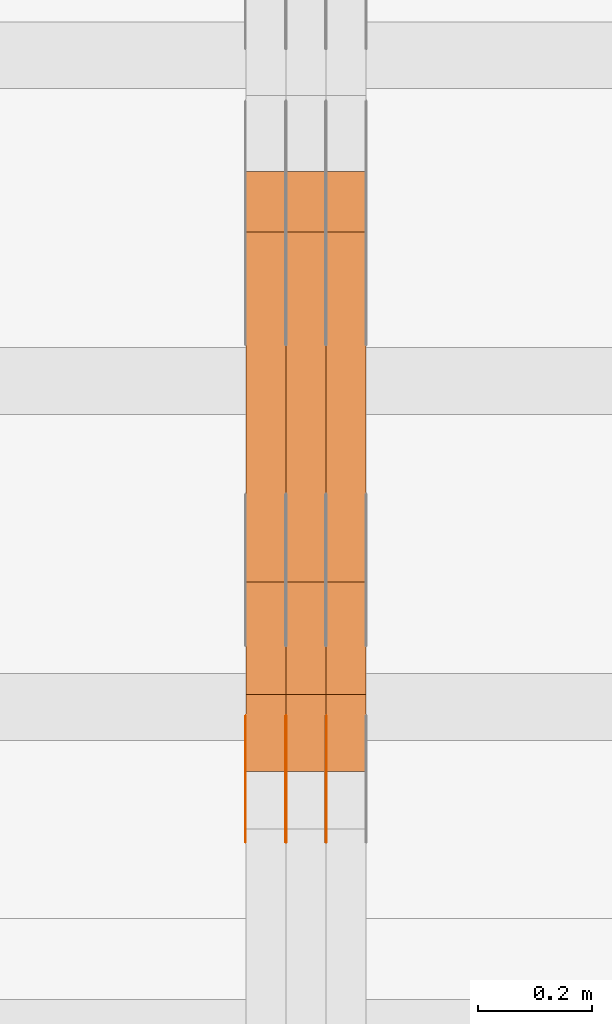
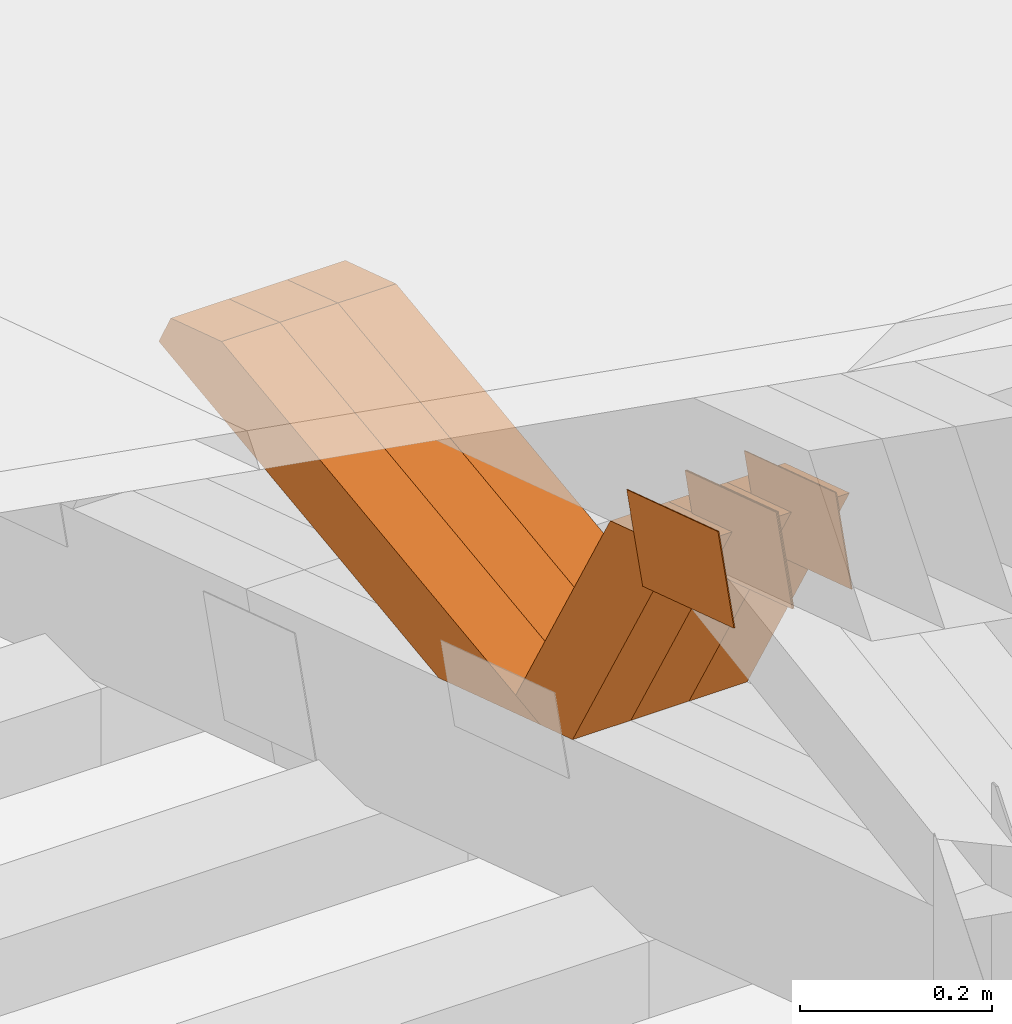
# One storey, part 169 of 385: 10 proxies.
"""IFC2X3 building model written with IfcOpenShell, lengths in millimetres."""

from ifc_helpers import new_model, entity, si_unit, converted_unit, derived_unit, direction, frame, origin, place, context, subcontext, project, spatial, polyline, outline, extrude, source, transform, mapped, material, type_object, type_shapes, element, save


model = new_model("IFC2X3")

# Units and contexts
model_context = context("Model", 3, precision=0.01, world=origin(), true_north=direction((6.12303176911189e-17, 1.0)))
body_context = subcontext(model_context, "Body", "Model", "MODEL_VIEW")
ifc_project = project(units=[si_unit("LENGTHUNIT", "METRE", prefix="MILLI"), si_unit("AREAUNIT", "SQUARE_METRE"), si_unit("VOLUMEUNIT", "CUBIC_METRE"), converted_unit("PLANEANGLEUNIT", "DEGREE", entity("IfcRatioMeasure", 0.0174532925199433), si_unit("PLANEANGLEUNIT", "RADIAN"), dimensions=[0, 0, 0, 0, 0, 0, 0]), si_unit("MASSUNIT", "GRAM", prefix="KILO"), derived_unit("MASSDENSITYUNIT", [(si_unit("MASSUNIT", "GRAM", prefix="KILO"), 1), (si_unit("LENGTHUNIT", "METRE"), -3)]), si_unit("TIMEUNIT", "SECOND"), si_unit("FREQUENCYUNIT", "HERTZ"), si_unit("THERMODYNAMICTEMPERATUREUNIT", "DEGREE_CELSIUS"), derived_unit("THERMALTRANSMITTANCEUNIT", [(si_unit("MASSUNIT", "GRAM", prefix="KILO"), 1), (si_unit("THERMODYNAMICTEMPERATUREUNIT", "KELVIN"), -1), (si_unit("TIMEUNIT", "SECOND"), -3)]), derived_unit("VOLUMETRICFLOWRATEUNIT", [(si_unit("LENGTHUNIT", "METRE"), 3), (si_unit("TIMEUNIT", "SECOND"), -1)]), si_unit("ELECTRICCURRENTUNIT", "AMPERE"), si_unit("ELECTRICVOLTAGEUNIT", "VOLT"), si_unit("POWERUNIT", "WATT"), si_unit("FORCEUNIT", "NEWTON", prefix="KILO"), si_unit("ILLUMINANCEUNIT", "LUX"), si_unit("LUMINOUSFLUXUNIT", "LUMEN"), si_unit("LUMINOUSINTENSITYUNIT", "CANDELA"), derived_unit("USERDEFINED", [(si_unit("MASSUNIT", "GRAM", prefix="KILO"), -1), (si_unit("LENGTHUNIT", "METRE"), -2), (si_unit("TIMEUNIT", "SECOND"), 3), (si_unit("LUMINOUSFLUXUNIT", "LUMEN"), 1)]), derived_unit("LINEARVELOCITYUNIT", [(si_unit("LENGTHUNIT", "METRE"), 1), (si_unit("TIMEUNIT", "SECOND"), -1)]), si_unit("PRESSUREUNIT", "PASCAL"), derived_unit("USERDEFINED", [(si_unit("LENGTHUNIT", "METRE"), -2), (si_unit("MASSUNIT", "GRAM", prefix="KILO"), 1), (si_unit("TIMEUNIT", "SECOND"), -2)])], contexts=[model_context])

# Site, building, storey
site_placement = place(None, origin())
site = spatial("IfcSite", under=ifc_project, at=site_placement, CompositionType="ELEMENT")
building_placement = place(site_placement, origin())
building = spatial("IfcBuilding", under=site, at=building_placement, CompositionType="ELEMENT")
storey_placement = place(building_placement, origin())
storey = spatial("IfcBuildingStorey", under=building, at=storey_placement, Name="Default", CompositionType="ELEMENT", Elevation=0.0)

# Proxies
ifc_material_1 = material(Name="IfcSurfaceStyle #370584")
building_element_proxy_type_1 = type_object("IfcBuildingElementProxyType", PredefinedType="NOTDEFINED", material=ifc_material_1)
shared_shape_1 = source(origin(), body_context, "Body", "SweptSolid", [
    extrude(outline(polyline([(-99.9999427841299, -54.0000599375792), (99.9996549037756, -54.0000599375792), (100.000407167194, 54.0000599375792), (-100.00011928684, 54.0000599375792), (-99.9999427841299, -54.0000599375792)])), frame((100.000407167194, 54.0000599375792, 0.0), z_axis=(0.0, 0.0, 1.0), x_axis=(-1.0, 0.0, 0.0)), (0.0, 0.0, 1.0), 1.3),
])
type_shapes(building_element_proxy_type_1, [shared_shape_1])
proxy_1_placement = place(building_placement, frame((30316.3, 18065.0682492591, 3072.55239547302), z_axis=(-1.0, 0.0, 0.0), x_axis=(0.0, -0.951056516295154, 0.309016994374948)))
element("IfcBuildingElementProxy", 1, at=proxy_1_placement, inside=storey, type_object=building_element_proxy_type_1, material=ifc_material_1, context=body_context, shape_type="MappedRepresentation", body=[
    mapped(shared_shape_1, transform((0.0, 0.0, 0.0), scale=1.0)),
])
ifc_material_2 = material(Name="IfcSurfaceStyle #370527")
building_element_proxy_type_2 = type_object("IfcBuildingElementProxyType", PredefinedType="NOTDEFINED", material=ifc_material_2)
shared_shape_2 = source(origin(), body_context, "Body", "SweptSolid", [
    extrude(outline(polyline([(-99.9999427841299, -54.0000599375792), (99.9996549037756, -54.0000599375792), (100.000407167194, 54.0000599375792), (-100.00011928684, 54.0000599375792), (-99.9999427841299, -54.0000599375792)])), frame((100.000407167194, 54.0000599375792, 0.0), z_axis=(0.0, 0.0, 1.0), x_axis=(-1.0, 0.0, 0.0)), (0.0, 0.0, 1.0), 1.29999999999998),
])
type_shapes(building_element_proxy_type_2, [shared_shape_2])
proxy_2_placement = place(building_placement, frame((30245.0, 18065.0682492591, 3072.55239547302), z_axis=(-1.0, 0.0, 0.0), x_axis=(0.0, -0.951056516295154, 0.309016994374948)))
element("IfcBuildingElementProxy", 2, at=proxy_2_placement, inside=storey, type_object=building_element_proxy_type_2, material=ifc_material_2, context=body_context, shape_type="MappedRepresentation", body=[
    mapped(shared_shape_2, transform((0.0, 0.0, 0.0), scale=1.0)),
])
ifc_material_3 = material(Name="IfcSurfaceStyle #370470")
building_element_proxy_type_3 = type_object("IfcBuildingElementProxyType", PredefinedType="NOTDEFINED", material=ifc_material_3)
shared_shape_3 = source(origin(), body_context, "Body", "SweptSolid", [
    extrude(outline(polyline([(-99.9999427841299, -54.0000599375792), (99.9996549037756, -54.0000599375792), (100.000407167194, 54.0000599375792), (-100.00011928684, 54.0000599375792), (-99.9999427841299, -54.0000599375792)])), frame((100.000407167194, 54.0000599375792, 0.0), z_axis=(0.0, 0.0, 1.0), x_axis=(-1.0, 0.0, 0.0)), (0.0, 0.0, 1.0), 1.29999999999998),
])
type_shapes(building_element_proxy_type_3, [shared_shape_3])
proxy_3_placement = place(building_placement, frame((30246.3, 18065.0682492591, 3072.55239547302), z_axis=(-1.0, 0.0, 0.0), x_axis=(0.0, -0.951056516295154, 0.309016994374948)))
element("IfcBuildingElementProxy", 3, at=proxy_3_placement, inside=storey, type_object=building_element_proxy_type_3, material=ifc_material_3, context=body_context, shape_type="MappedRepresentation", body=[
    mapped(shared_shape_3, transform((0.0, 0.0, 0.0), scale=1.0)),
])
ifc_material_4 = material(Name="IfcSurfaceStyle #370413")
building_element_proxy_type_4 = type_object("IfcBuildingElementProxyType", PredefinedType="NOTDEFINED", material=ifc_material_4)
shared_shape_4 = source(origin(), body_context, "Body", "SweptSolid", [
    extrude(outline(polyline([(-99.9999427841299, -54.0000599375792), (99.9996549037756, -54.0000599375792), (100.000407167194, 54.0000599375792), (-100.00011928684, 54.0000599375792), (-99.9999427841299, -54.0000599375792)])), frame((100.000407167194, 54.0000599375792, 0.0), z_axis=(0.0, 0.0, 1.0), x_axis=(-1.0, 0.0, 0.0)), (0.0, 0.0, 1.0), 1.29999999999999),
])
type_shapes(building_element_proxy_type_4, [shared_shape_4])
proxy_4_placement = place(building_placement, frame((30175.0, 18065.0682492591, 3072.55239547302), z_axis=(-1.0, 0.0, 0.0), x_axis=(0.0, -0.951056516295154, 0.309016994374948)))
element("IfcBuildingElementProxy", 4, at=proxy_4_placement, inside=storey, type_object=building_element_proxy_type_4, material=ifc_material_4, context=body_context, shape_type="MappedRepresentation", body=[
    mapped(shared_shape_4, transform((0.0, 0.0, 0.0), scale=1.0)),
])
ifc_material_5 = material(Name="IfcSurfaceStyle #360546")
building_element_proxy_type_5 = type_object("IfcBuildingElementProxyType", Name="T1-W35 360544", PredefinedType="NOTDEFINED", material=ifc_material_5)
shared_shape_5 = source(origin(), body_context, "Body", "SweptSolid", [
    extrude(outline(polyline([(-196.877231354918, -47.499850828051), (197.289756738813, -47.499850828051), (177.380838136073, -0.000131002767018074), (124.615181369032, 47.4999163294346), (-302.408544889, 47.4999163294346), (-196.877231354918, -47.499850828051)])), frame((197.289756738813, 47.5002438363521, 0.0), z_axis=(0.0, 0.0, 1.0), x_axis=(-1.0, 0.0, 0.0)), (0.0, 0.0, 1.0), 70.0),
])
type_shapes(building_element_proxy_type_5, [shared_shape_5])
proxy_5_placement = place(building_placement, frame((30385.0, 18249.5528960018, 2724.16980022534), z_axis=(-1.0, 0.0, 0.0), x_axis=(0.0, -0.5, 0.866025403784439)))
element("IfcBuildingElementProxy", 5, at=proxy_5_placement, inside=storey, type_object=building_element_proxy_type_5, material=ifc_material_5, Name="T1-W35", context=body_context, shape_type="MappedRepresentation", body=[
    mapped(shared_shape_5, transform((0.0, 0.0, 0.0), scale=1.0)),
])
ifc_material_6 = material(Name="IfcSurfaceStyle #360480")
building_element_proxy_type_6 = type_object("IfcBuildingElementProxyType", Name="T1-W35 360478", PredefinedType="NOTDEFINED", material=ifc_material_6)
shared_shape_6 = source(origin(), body_context, "Body", "SweptSolid", [
    extrude(outline(polyline([(-196.877231354918, -47.499850828051), (197.289756738813, -47.499850828051), (177.380838136073, -0.000131002767018074), (124.615181369032, 47.4999163294346), (-302.408544889, 47.4999163294346), (-196.877231354918, -47.499850828051)])), frame((197.289756738813, 47.5002438363521, 0.0), z_axis=(0.0, 0.0, 1.0), x_axis=(-1.0, 0.0, 0.0)), (0.0, 0.0, 1.0), 70.0),
])
type_shapes(building_element_proxy_type_6, [shared_shape_6])
proxy_6_placement = place(building_placement, frame((30315.0, 18249.5528960018, 2724.16980022534), z_axis=(-1.0, 0.0, 0.0), x_axis=(0.0, -0.5, 0.866025403784439)))
element("IfcBuildingElementProxy", 6, at=proxy_6_placement, inside=storey, type_object=building_element_proxy_type_6, material=ifc_material_6, Name="T1-W35", context=body_context, shape_type="MappedRepresentation", body=[
    mapped(shared_shape_6, transform((0.0, 0.0, 0.0), scale=1.0)),
])
ifc_material_7 = material(Name="IfcSurfaceStyle #360414")
building_element_proxy_type_7 = type_object("IfcBuildingElementProxyType", Name="T1-W35 360412", PredefinedType="NOTDEFINED", material=ifc_material_7)
shared_shape_7 = source(origin(), body_context, "Body", "SweptSolid", [
    extrude(outline(polyline([(-196.877231354918, -47.499850828051), (197.289756738813, -47.499850828051), (177.380838136073, -0.000131002767018074), (124.615181369032, 47.4999163294346), (-302.408544889, 47.4999163294346), (-196.877231354918, -47.499850828051)])), frame((197.289756738813, 47.5002438363521, 0.0), z_axis=(0.0, 0.0, 1.0), x_axis=(-1.0, 0.0, 0.0)), (0.0, 0.0, 1.0), 70.0),
])
type_shapes(building_element_proxy_type_7, [shared_shape_7])
proxy_7_placement = place(building_placement, frame((30245.0, 18249.5528960018, 2724.16980022534), z_axis=(-1.0, 0.0, 0.0), x_axis=(0.0, -0.5, 0.866025403784439)))
element("IfcBuildingElementProxy", 7, at=proxy_7_placement, inside=storey, type_object=building_element_proxy_type_7, material=ifc_material_7, Name="T1-W35", context=body_context, shape_type="MappedRepresentation", body=[
    mapped(shared_shape_7, transform((0.0, 0.0, 0.0), scale=1.0)),
])
ifc_material_8 = material(Name="IfcSurfaceStyle #360150")
building_element_proxy_type_8 = type_object("IfcBuildingElementProxyType", Name="T1-W6 360148", PredefinedType="NOTDEFINED", material=ifc_material_8)
shared_shape_8 = source(origin(), body_context, "Body", "SweptSolid", [
    extrude(outline(polyline([(-485.945461934772, -47.500204767976), (183.41906495488, -47.500204767976), (284.061400026172, 0.000179660053988773), (303.127757064591, 47.500114937949), (-284.66276011087, 47.500114937949), (-485.945461934772, -47.500204767976)])), frame((303.127970456024, 47.5001450766485, 0.0), z_axis=(0.0, 0.0, 1.0), x_axis=(-1.0, 0.0, 0.0)), (0.0, 0.0, 1.0), 70.0),
])
type_shapes(building_element_proxy_type_8, [shared_shape_8])
proxy_8_placement = place(building_placement, frame((30385.0, 19075.4826373647, 2770.72729201433), z_axis=(-1.0, 0.0, 0.0), x_axis=(0.0, -0.991969529622927, -0.126477082112413)))
element("IfcBuildingElementProxy", 8, at=proxy_8_placement, inside=storey, type_object=building_element_proxy_type_8, material=ifc_material_8, Name="T1-W6", context=body_context, shape_type="MappedRepresentation", body=[
    mapped(shared_shape_8, transform((0.0, 0.0, 0.0), scale=1.0)),
])
ifc_material_9 = material(Name="IfcSurfaceStyle #360084")
building_element_proxy_type_9 = type_object("IfcBuildingElementProxyType", Name="T1-W6 360082", PredefinedType="NOTDEFINED", material=ifc_material_9)
shared_shape_9 = source(origin(), body_context, "Body", "SweptSolid", [
    extrude(outline(polyline([(-485.945461934772, -47.500204767976), (183.41906495488, -47.500204767976), (284.061400026172, 0.000179660053988773), (303.127757064591, 47.500114937949), (-284.66276011087, 47.500114937949), (-485.945461934772, -47.500204767976)])), frame((303.127970456024, 47.5001450766485, 0.0), z_axis=(0.0, 0.0, 1.0), x_axis=(-1.0, 0.0, 0.0)), (0.0, 0.0, 1.0), 70.0),
])
type_shapes(building_element_proxy_type_9, [shared_shape_9])
proxy_9_placement = place(building_placement, frame((30315.0, 19075.4826373647, 2770.72729201433), z_axis=(-1.0, 0.0, 0.0), x_axis=(0.0, -0.991969529622927, -0.126477082112413)))
element("IfcBuildingElementProxy", 9, at=proxy_9_placement, inside=storey, type_object=building_element_proxy_type_9, material=ifc_material_9, Name="T1-W6", context=body_context, shape_type="MappedRepresentation", body=[
    mapped(shared_shape_9, transform((0.0, 0.0, 0.0), scale=1.0)),
])
ifc_material_10 = material(Name="IfcSurfaceStyle #360018")
building_element_proxy_type_10 = type_object("IfcBuildingElementProxyType", Name="T1-W6 360016", PredefinedType="NOTDEFINED", material=ifc_material_10)
shared_shape_10 = source(origin(), body_context, "Body", "SweptSolid", [
    extrude(outline(polyline([(-485.945461934772, -47.500204767976), (183.41906495488, -47.500204767976), (284.061400026172, 0.000179660053988773), (303.127757064591, 47.500114937949), (-284.66276011087, 47.500114937949), (-485.945461934772, -47.500204767976)])), frame((303.127970456024, 47.5001450766485, 0.0), z_axis=(0.0, 0.0, 1.0), x_axis=(-1.0, 0.0, 0.0)), (0.0, 0.0, 1.0), 70.0),
])
type_shapes(building_element_proxy_type_10, [shared_shape_10])
proxy_10_placement = place(building_placement, frame((30245.0, 19075.4826373647, 2770.72729201433), z_axis=(-1.0, 0.0, 0.0), x_axis=(0.0, -0.991969529622927, -0.126477082112413)))
element("IfcBuildingElementProxy", 10, at=proxy_10_placement, inside=storey, type_object=building_element_proxy_type_10, material=ifc_material_10, Name="T1-W6", context=body_context, shape_type="MappedRepresentation", body=[
    mapped(shared_shape_10, transform((0.0, 0.0, 0.0), scale=1.0)),
])

save(model, "model.ifc")
